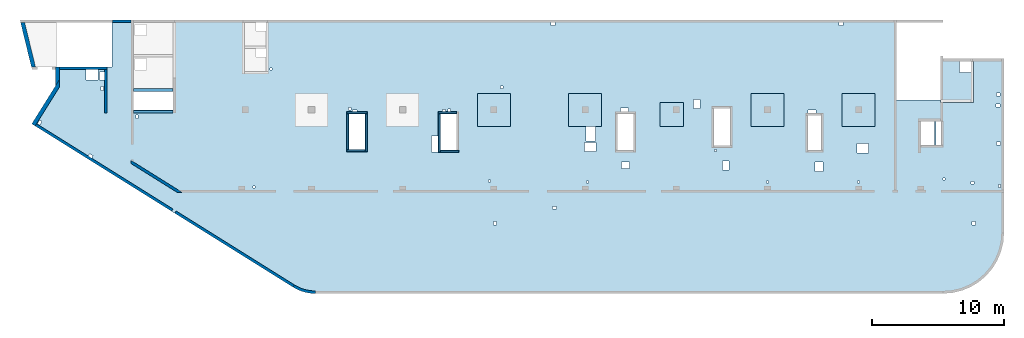
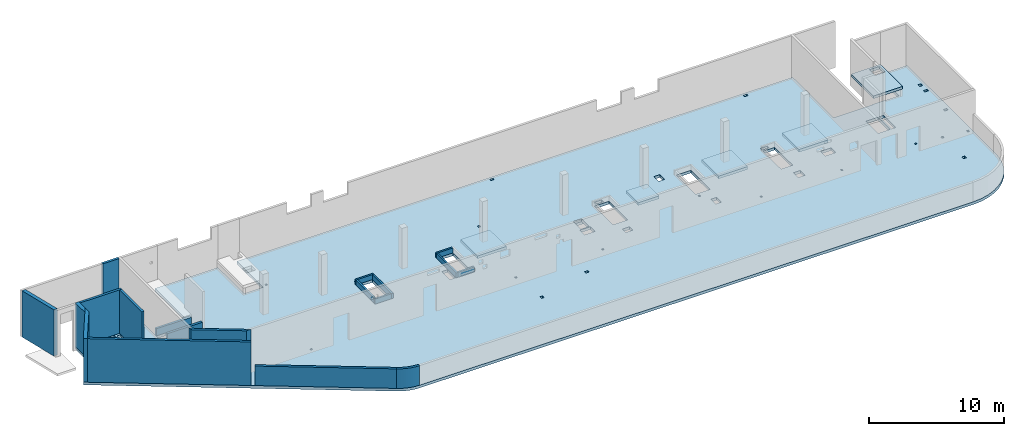
# One storey, part 2 of 6: 19 walls, 7 slabs.
"""IFC4 building model written with IfcOpenShell, lengths in millimetres."""

from ifc_helpers import new_model, entity, si_unit, converted_unit, derived_unit, direction, frame, origin, place, context, subcontext, project, spatial, indexed_curve, outline, extrude, material, type_object, element, save


model = new_model("IFC4")

# Units and contexts
model_context = context("Model", 3, precision=0.01, world=origin(), true_north=direction((6.12303176911189e-17, 1.0)))
plan_context = context("Plan", 3, precision=0.01, world=origin(), true_north=direction((6.12303176911189e-17, 1.0)))
body_context = subcontext(model_context, "Body", "Model", "MODEL_VIEW")
ifc_project = project(units=[si_unit("LENGTHUNIT", "METRE", prefix="MILLI"), si_unit("AREAUNIT", "SQUARE_METRE"), si_unit("VOLUMEUNIT", "CUBIC_METRE"), converted_unit("PLANEANGLEUNIT", "DEGREE", entity("IfcRatioMeasure", 0.0174532925199433), si_unit("PLANEANGLEUNIT", "RADIAN"), dimensions=[0, 0, 0, 0, 0, 0, 0]), si_unit("MASSUNIT", "GRAM", prefix="KILO"), derived_unit("MASSDENSITYUNIT", [(si_unit("MASSUNIT", "GRAM", prefix="KILO"), 1), (si_unit("LENGTHUNIT", "METRE"), -3)]), derived_unit("MOMENTOFINERTIAUNIT", [(si_unit("LENGTHUNIT", "METRE"), 4)]), si_unit("TIMEUNIT", "SECOND"), si_unit("FREQUENCYUNIT", "HERTZ"), si_unit("THERMODYNAMICTEMPERATUREUNIT", "DEGREE_CELSIUS"), derived_unit("THERMALTRANSMITTANCEUNIT", [(si_unit("MASSUNIT", "GRAM", prefix="KILO"), 1), (si_unit("THERMODYNAMICTEMPERATUREUNIT", "KELVIN"), -1), (si_unit("TIMEUNIT", "SECOND"), -3)]), derived_unit("VOLUMETRICFLOWRATEUNIT", [(si_unit("LENGTHUNIT", "METRE"), 3), (si_unit("TIMEUNIT", "SECOND"), -1)]), derived_unit("MASSFLOWRATEUNIT", [(si_unit("MASSUNIT", "GRAM", prefix="KILO"), 1), (si_unit("TIMEUNIT", "SECOND"), -1)]), derived_unit("ROTATIONALFREQUENCYUNIT", [(si_unit("TIMEUNIT", "SECOND"), -1)]), si_unit("ELECTRICCURRENTUNIT", "AMPERE"), si_unit("ELECTRICVOLTAGEUNIT", "VOLT"), si_unit("POWERUNIT", "WATT"), si_unit("FORCEUNIT", "NEWTON", prefix="KILO"), si_unit("ILLUMINANCEUNIT", "LUX"), si_unit("LUMINOUSFLUXUNIT", "LUMEN"), si_unit("LUMINOUSINTENSITYUNIT", "CANDELA"), derived_unit("USERDEFINED", [(si_unit("MASSUNIT", "GRAM", prefix="KILO"), -1), (si_unit("LENGTHUNIT", "METRE"), -2), (si_unit("TIMEUNIT", "SECOND"), 3), (si_unit("LUMINOUSFLUXUNIT", "LUMEN"), 1)]), derived_unit("LINEARVELOCITYUNIT", [(si_unit("LENGTHUNIT", "METRE"), 1), (si_unit("TIMEUNIT", "SECOND"), -1)]), si_unit("PRESSUREUNIT", "PASCAL"), derived_unit("USERDEFINED", [(si_unit("LENGTHUNIT", "METRE"), -2), (si_unit("MASSUNIT", "GRAM", prefix="KILO"), 1), (si_unit("TIMEUNIT", "SECOND"), -2)]), derived_unit("LINEARFORCEUNIT", [(si_unit("MASSUNIT", "GRAM", prefix="KILO"), 1), (si_unit("LENGTHUNIT", "METRE"), 1), (si_unit("TIMEUNIT", "SECOND"), -2), (si_unit("LENGTHUNIT", "METRE"), -1)]), derived_unit("PLANARFORCEUNIT", [(si_unit("MASSUNIT", "GRAM", prefix="KILO"), 1), (si_unit("LENGTHUNIT", "METRE"), 1), (si_unit("TIMEUNIT", "SECOND"), -2), (si_unit("LENGTHUNIT", "METRE"), -2)])], contexts=[model_context, plan_context])

# Site, building, storey
site_placement = place(None, origin())
site = spatial("IfcSite", under=ifc_project, at=site_placement, CompositionType="ELEMENT")
building_placement = place(site_placement, origin())
building = spatial("IfcBuilding", under=site, at=building_placement, CompositionType="ELEMENT")
storey_placement = place(building_placement, frame((0.0, 0.0, 28200.0)))
storey = spatial("IfcBuildingStorey", under=building, at=storey_placement, CompositionType="ELEMENT", Elevation=28200.0)

# Slabs
ifc_material = material()
slab_type_1 = type_object("IfcSlabType", PredefinedType="FLOOR", material=ifc_material)
slab_1_placement = place(storey_placement, origin())
element("IfcSlab", 1, at=slab_1_placement, inside=storey, type_object=slab_type_1, material=ifc_material, PredefinedType="FLOOR", context=body_context, shape_type="SweptSolid", body=[
    extrude(outline(indexed_curve([(-9938.81931383592, -15994.6889933943), (-9785.18945223826, -16084.8814308087), (-9626.77631531153, -16166.380438105), (-9464.0713398645, -16238.9331851656), (-9297.57927705262, -16302.3145953889), (-9127.81662651489, -16356.3280439333), (-8955.31003406395, -16400.8059676958), (-8780.59465790024, -16435.6103851342), (-8604.21250841868, -16460.6333243205), (-8426.71076675808, -16475.797157896), (-8248.64008730964, -16481.0548438912), (39261.8400680731, -16481.0548438912), (39981.4384793149, -16424.4212206982), (40683.3179894618, -16255.9148588784), (41350.1959955693, -15979.6849443003), (41965.6517478859, -15602.5331742155), (42514.530683209, -15133.7462768982), (42983.3175805262, -14584.8673415751), (43360.4693506111, -13969.4115892585), (43636.6992651892, -13302.533583151), (43805.205627009, -12600.6540730041), (43861.839250202, -11881.0556617623), (43861.839250202, 1288.94433823765), (41361.839250202, 1288.94433823766), (41361.839250202, -1811.05566176234), (39061.8400680731, -1811.05566176233), (39061.8400680731, -1851.05566176232), (35721.8400680731, -1851.05566176231), (35721.8400680732, 4218.94497760487), (-11983.1599319269, 4218.94497760503), (-11983.1599319269, 318.944338238026), (-13608.1599319269, 318.944338238032), (-13608.1599319269, 4218.94497760487), (-19008.1599319269, 4218.94497760488), (-19008.1599319269, -981.05502239514), (-22008.1599319269, -981.055022395131), (-22008.1599319269, 4218.94497760487), (-23638.1599319269, 4218.94497760487), (-23638.1599319269, 678.944338238106), (-27903.1599319269, 678.944338238122), (-27903.1599319269, -752.702496972901), (-29708.3002878078, -3641.58731781876), (-9938.81931383592, -15994.6889933943)], self_intersect=False), holes=[indexed_curve([(-24693.1599319269, 478.944338238115), (-24693.1599319269, -321.055661761885), (-25623.1599319269, -321.055661761885), (-25623.1599319269, 478.944338238115), (-24693.1599319269, 478.944338238115)], self_intersect=False), indexed_curve([(-24573.1599319269, -311.055661761892), (-24573.1599319269, 288.944338238108), (-24208.1599319269, 288.944338238108), (-24208.1599319269, -311.055661761892), (-24573.1599319269, -311.055661761892)], self_intersect=False), indexed_curve([(-24268.1599319269, -821.055661761893), (-24268.1599319269, -1121.05566176189), (-24468.1599319269, -1121.05566176189), (-24468.1599319269, -821.055661761893), (-24268.1599319269, -821.055661761893)], self_intersect=False), indexed_curve([(-29120.030322959, -3360.6274479853), (-28950.4197742035, -3466.6098132677), (-29109.3933221271, -3721.02563640098), (-29279.0038708826, -3615.04327111857), (-29120.030322959, -3360.6274479853)], self_intersect=False), indexed_curve([(-25332.3965852951, -5904.23328799078), (-25077.9807621618, -6063.20683591438), (-25183.9631274442, -6232.8173846699), (-25438.3789505775, -6073.84383674629), (-25332.3965852951, -5904.23328799078)], self_intersect=False), indexed_curve([(-21683.1599319269, -2966.05566176191), (-21683.1599319269, -3216.05566176191), (-21833.1599319269, -3216.05566176191), (-21833.1599319269, -2966.05566176191), (-21683.1599319269, -2966.05566176191)], self_intersect=False), indexed_curve([(-11548.1599319269, 573.944338238028), (-11548.1599319269, 423.944338238028), (-11698.1599319269, 423.944338238028), (-11698.1599319269, 573.944338238028), (-11548.1599319269, 573.944338238028)], self_intersect=False), indexed_curve([(43571.839250202, -2146.05566176235), (43571.839250202, -2346.05566176235), (43271.839250202, -2346.05566176235), (43271.839250202, -2146.05566176236), (43571.839250202, -2146.05566176235)], self_intersect=False), indexed_curve([(43561.839250202, -1291.05566176236), (43561.839250202, -1541.05566176236), (43311.839250202, -1541.05566176235), (43311.839250202, -1291.05566176236), (43561.839250202, -1291.05566176236)], self_intersect=False), indexed_curve([(43611.839250202, -5031.05566176235), (43611.839250202, -5231.05566176235), (43311.839250202, -5231.05566176235), (43311.839250202, -5031.05566176235), (43611.839250202, -5031.05566176235)], self_intersect=False), indexed_curve([(43586.839250202, -8246.05566176236), (43586.839250202, -8446.05566176236), (43436.839250202, -8446.05566176236), (43436.839250202, -8246.05566176236), (43586.839250202, -8246.05566176236)], self_intersect=False), indexed_curve([(41581.839250202, -7991.05566176235), (41581.839250202, -8191.05566176235), (41381.839250202, -8191.05566176235), (41381.839250202, -7991.05566176235), (41581.839250202, -7991.05566176235)], self_intersect=False), indexed_curve([(39396.8400680731, -7746.05566176233), (39396.8400680731, -7896.05566176233), (39246.8400680731, -7896.05566176233), (39246.8400680731, -7746.05566176233), (39396.8400680731, -7746.05566176233)], self_intersect=False), indexed_curve([(41686.839250202, -11031.0556617623), (41686.839250202, -11281.0556617623), (41436.839250202, -11281.0556617623), (41436.839250202, -11031.0556617623), (41686.839250202, -11031.0556617623)], self_intersect=False), indexed_curve([(5461.84006807309, -11031.0556617622), (5461.84006807309, -11281.0556617622), (5211.84006807308, -11281.0556617622), (5211.84006807309, -11031.0556617622), (5461.84006807309, -11031.0556617622)], self_intersect=False), indexed_curve([(10011.8400680731, -9881.05566176212), (10011.8400680731, -10081.0556617621), (9711.84006807309, -10081.0556617621), (9711.84006807309, -9881.05566176212), (10011.8400680731, -9881.05566176212)], self_intersect=False), indexed_curve([(32936.8400680731, -8101.05566176228), (32786.8400680731, -8101.05566176228), (32786.8400680731, -7951.05566176228), (32936.8400680731, -7951.05566176228), (32936.8400680731, -8101.05566176228)], self_intersect=False), indexed_curve([(33621.8400680731, -5141.05566176228), (33621.8400680731, -5841.05566176228), (32721.8400680731, -5841.05566176228), (32721.8400680731, -5141.05566176227), (33621.8400680731, -5141.05566176228)], self_intersect=False), indexed_curve([(30166.8400680731, -6541.05566176228), (30166.8400680731, -7241.05566176228), (29566.8400680731, -7241.05566176227), (29566.8400680731, -6541.05566176227), (30166.8400680731, -6541.05566176228)], self_intersect=False), indexed_curve([(26036.8400680731, -8101.05566176226), (25886.8400680731, -8101.05566176226), (25886.8400680731, -7951.05566176226), (26036.8400680731, -7951.05566176226), (26036.8400680731, -8101.05566176226)], self_intersect=False), indexed_curve([(12411.8400680731, -8121.05566176221), (12261.8400680731, -8121.05566176222), (12261.8400680731, -7971.05566176221), (12411.8400680731, -7971.05566176221), (12411.8400680731, -8121.05566176221)], self_intersect=False), indexed_curve([(5001.8400680731, -8041.05566176219), (4851.84006807309, -8041.05566176219), (4851.84006807309, -7891.05566176219), (5001.84006807309, -7891.05566176219), (5001.8400680731, -8041.05566176219)], self_intersect=False), indexed_curve([(-12818.1599319269, -8506.05566176197), (-12968.1599319269, -8506.05566176196), (-12968.1599319269, -8356.05566176196), (-12818.1599319269, -8356.05566176196), (-12818.1599319269, -8506.05566176197)], self_intersect=False), indexed_curve([(29021.8400680731, -5656.05566176226), (29021.8400680731, -2986.05566176226), (30021.8400680731, -2986.05566176226), (30021.8400680731, -5656.05566176226), (29021.8400680731, -5656.05566176226)], self_intersect=False), indexed_curve([(29021.8400680731, -2581.05566176225), (29621.8400680731, -2581.05566176225), (29621.8400680731, -2836.05566176225), (29021.8400680731, -2836.05566176226), (29021.8400680731, -2581.05566176225)], self_intersect=False), indexed_curve([(23041.8400680731, -6446.05566176221), (23041.8400680731, -7146.05566176222), (22541.8400680731, -7146.05566176222), (22541.8400680731, -6446.05566176221), (23041.8400680731, -6446.05566176221)], self_intersect=False), indexed_curve([(22096.8400680731, -5571.05566176221), (22096.8400680731, -5721.05566176221), (21946.8400680731, -5721.05566176221), (21946.8400680731, -5571.05566176221), (22096.8400680731, -5571.05566176221)], self_intersect=False), indexed_curve([(23141.8400680731, -2446.05566176221), (23141.8400680731, -5306.05566176222), (21881.8400680731, -5306.05566176221), (21881.8400680731, -2446.0556617622), (23141.8400680731, -2446.05566176221)], self_intersect=False), indexed_curve([(38611.8400680731, -3451.05566176231), (38611.8400680731, -5256.05566176231), (37571.8400680731, -5256.05566176231), (37571.8400680731, -3451.05566176231), (38611.8400680731, -3451.05566176231)], self_intersect=False), indexed_curve([(39111.8400680731, -3451.05566176232), (39111.8400680731, -5256.05566176232), (38731.8400680731, -5256.05566176232), (38731.8400680731, -3451.05566176232), (39061.8400680731, -3451.05566176232), (39111.8400680731, -3451.05566176232)], self_intersect=False), indexed_curve([(-4458.15993192693, -2881.05566176151), (-4458.15993192693, -5591.05566176151), (-5718.15993192693, -5591.05566176151), (-5718.15993192693, -2881.05566176151), (-4458.15993192693, -2881.05566176151)], self_intersect=False), indexed_curve([(-5088.15993192693, -2581.05566176152), (-5088.15993192693, -2731.05566176152), (-5438.15993192692, -2731.05566176152), (-5438.15993192693, -2581.05566176151), (-5088.15993192693, -2581.05566176152)], self_intersect=False), indexed_curve([(-5538.15993192693, -2391.05566176151), (-5538.15993192693, -2591.05566176151), (-5738.15993192693, -2591.05566176151), (-5738.15993192693, -2391.05566176151), (-5538.15993192693, -2391.05566176151)], self_intersect=False), indexed_curve([(1616.84006807306, -2561.05566176154), (1616.84006807306, -2711.05566176153), (1366.84006807306, -2711.05566176153), (1366.84006807306, -2561.05566176153), (1616.84006807306, -2561.05566176154)], self_intersect=False), indexed_curve([(2461.84006807306, -2881.05566176156), (2461.84006807306, -5656.05566176156), (1201.84006807306, -5656.05566176156), (1201.84006807307, -2881.05566176156), (2461.84006807306, -2881.05566176156)], self_intersect=False), indexed_curve([(1981.84006807306, -2531.05566176156), (1981.84006807306, -2731.05566176156), (1781.84006807306, -2731.05566176156), (1781.84006807306, -2531.05566176156), (1981.84006807306, -2531.05566176156)], self_intersect=False), indexed_curve([(1031.84006807307, -4561.05566176155), (1031.84006807307, -5761.05566176155), (531.840068073072, -5761.05566176155), (531.840068073072, -4561.05566176155), (1031.84006807307, -4561.05566176155)], self_intersect=False), indexed_curve([(5961.84006807306, -771.055661761588), (5961.84006807306, -971.055661761588), (5761.84006807306, -971.055661761592), (5761.84006807306, -771.05566176159), (5961.84006807306, -771.055661761588)], self_intersect=False), indexed_curve([(12946.8400680731, -3831.05566176163), (12946.8400680731, -4951.05566176164), (12246.8400680731, -4951.05566176163), (12246.8400680731, -3831.05566176163), (12946.8400680731, -3831.05566176163)], self_intersect=False), indexed_curve([(13001.8400680731, -5046.05566176163), (13001.8400680731, -5746.05566176164), (12101.8400680731, -5746.05566176163), (12101.8400680731, -5046.05566176163), (13001.8400680731, -5046.05566176163)], self_intersect=False), indexed_curve([(15861.8400680731, -2881.05566176161), (15861.8400680731, -5656.05566176161), (14601.8400680731, -5656.05566176161), (14601.8400680731, -2881.05566176162), (15861.8400680731, -2881.05566176161)], self_intersect=False), indexed_curve([(15461.8400680731, -2451.05566176165), (15461.8400680731, -2731.05566176162), (14831.8400680731, -2731.05566176162), (14831.8400680731, -2451.05566176165), (15461.8400680731, -2451.05566176165)], self_intersect=False), indexed_curve([(15516.8400680731, -6511.05566176205), (15516.8400680731, -7011.05566176205), (14916.8400680731, -7011.05566176205), (14916.8400680731, -6511.05566176205), (15516.8400680731, -6511.05566176205)], self_intersect=False), indexed_curve([(20856.8400680731, -1786.05566176169), (20856.8400680731, -2486.05566176169), (20356.8400680731, -2486.05566176169), (20356.8400680731, -1786.0556617617), (20856.8400680731, -1786.05566176169)], self_intersect=False), indexed_curve([(9891.84006807312, 4018.94497760487), (9891.84006807312, 3818.94497760487), (9591.84006807312, 3818.94497760487), (9591.84006807312, 4018.94497760487), (9891.84006807312, 4018.94497760487)], self_intersect=False), indexed_curve([(31661.8400680731, 4018.944977605), (31661.8400680731, 3818.94497760499), (31361.8400680731, 3818.94497760499), (31361.8400680731, 4018.94497760499), (31661.8400680731, 4018.944977605)], self_intersect=False), indexed_curve([(-19008.1599319269, -1181.05502239513), (-19008.1599319269, -2581.05502239513), (-22008.1599319269, -2581.05502239513), (-22008.1599319269, -1181.05502239513), (-19008.1599319269, -1181.05502239513)], self_intersect=False)]), frame((29708.1602004816, 16281.0548881178, -400.0)), (0.0, 0.0, 1.0), 249.999999999999),
])
slab_type_2 = type_object("IfcSlabType", PredefinedType="FLOOR", material=ifc_material)
slab_2_placement = place(storey_placement, origin())
element("IfcSlab", 2, at=slab_2_placement, inside=storey, type_object=slab_type_2, material=ifc_material, PredefinedType="FLOOR", context=body_context, shape_type="SweptSolid", body=[
    extrude(outline(indexed_curve([(-1133.33296983506, -1466.66666666666), (-933.332969835079, -1466.66666666666), (1166.66621229381, -1466.66666666666), (1366.66621229383, -1466.66666666666), (1366.66621229383, 1633.33333333332), (1366.66621229383, 1833.33333333332), (-933.33296983507, 1833.33333333332), (-1133.33296983506, 1833.33333333332), (-1133.33296983506, -1266.66666666668), (-1133.33296983506, -1466.66666666666)], self_intersect=False), holes=[indexed_curve([(-933.33296983507, -1266.66666666667), (-933.33296983507, -416.666666666674), (-83.332969835073, -416.666666666674), (-83.332969835073, -1266.66666666667), (-933.33296983507, -1266.66666666667)], self_intersect=False)]), frame((70136.6664808485, 16103.3325596888, 500.0), z_axis=(0.0, 0.0, 1.0), x_axis=(-1.0, 0.0, 0.0)), (0.0, 0.0, 1.0), 249.999999999999),
])
slab_type_3 = type_object("IfcSlabType", PredefinedType="FLOOR", material=ifc_material)
slab_3_placement = place(storey_placement, origin())
element("IfcSlab", 3, at=slab_3_placement, inside=storey, type_object=slab_type_3, material=ifc_material, PredefinedType="FLOOR", context=body_context, shape_type="SweptSolid", body=[
    extrude(outline(indexed_curve([(-1250.0, -1250.0), (1250.0, -1250.0), (1250.0, 1250.0), (-1250.0, 1250.0), (-1250.0, -1250.0)], self_intersect=False)), frame((34970.0002685547, 13699.9992263563, -400.0), z_axis=(0.0, 0.0, -1.0), x_axis=(0.0, 1.0, 0.0)), (0.0, 0.0, 1.0), 249.999999999999),
])
slab_type_4 = type_object("IfcSlabType", PredefinedType="FLOOR", material=ifc_material)
slab_4_placement = place(storey_placement, origin())
element("IfcSlab", 4, at=slab_4_placement, inside=storey, type_object=slab_type_4, material=ifc_material, PredefinedType="FLOOR", context=body_context, shape_type="SweptSolid", body=[
    extrude(outline(indexed_curve([(-1250.0, -1250.0), (1250.0, -1250.0), (1250.0, 1250.0), (-1250.0, 1250.0), (-1250.0, -1250.0)], self_intersect=False)), frame((41870.0002685547, 13699.9992263563, -400.0), z_axis=(0.0, 0.0, -1.0), x_axis=(0.0, 1.0, 0.0)), (0.0, 0.0, 1.0), 249.999999999999),
])
slab_type_5 = type_object("IfcSlabType", PredefinedType="FLOOR", material=ifc_material)
slab_5_placement = place(storey_placement, origin())
element("IfcSlab", 5, at=slab_5_placement, inside=storey, type_object=slab_type_5, material=ifc_material, PredefinedType="FLOOR", context=body_context, shape_type="SweptSolid", body=[
    extrude(outline(indexed_curve([(-899.999999999934, -900.000000000003), (899.999999999936, -900.000000000003), (899.999999999936, 900.000000000003), (-899.999999999934, 900.000000000003), (-899.999999999934, -900.000000000003)], self_intersect=False)), frame((48420.0002685547, 13349.9992263562, -400.0), z_axis=(0.0, 0.0, -1.0), x_axis=(0.0, 1.0, 0.0)), (0.0, 0.0, 1.0), 249.999999999999),
])
slab_type_6 = type_object("IfcSlabType", PredefinedType="FLOOR", material=ifc_material)
slab_6_placement = place(storey_placement, origin())
element("IfcSlab", 6, at=slab_6_placement, inside=storey, type_object=slab_type_6, material=ifc_material, PredefinedType="FLOOR", context=body_context, shape_type="SweptSolid", body=[
    extrude(outline(indexed_curve([(-1250.0, -1250.00000000001), (1250.0, -1250.00000000001), (1250.0, 1249.99999999999), (-1250.0, 1249.99999999999), (-1250.0, -1250.00000000001)], self_intersect=False)), frame((55670.0002685547, 13699.9992263562, -400.0), z_axis=(0.0, 0.0, -1.0), x_axis=(0.0, 1.0, 0.0)), (0.0, 0.0, 1.0), 249.999999999999),
])
slab_type_7 = type_object("IfcSlabType", PredefinedType="FLOOR", material=ifc_material)
slab_7_placement = place(storey_placement, origin())
element("IfcSlab", 7, at=slab_7_placement, inside=storey, type_object=slab_type_7, material=ifc_material, PredefinedType="FLOOR", context=body_context, shape_type="SweptSolid", body=[
    extrude(outline(indexed_curve([(-1250.0, -1249.99999999999), (1250.0, -1249.99999999999), (1250.0, 1250.00000000001), (-1250.0, 1250.00000000001), (-1250.0, -1249.99999999999)], self_intersect=False)), frame((62570.0002685546, 13699.9992263562, -400.0), z_axis=(0.0, 0.0, -1.0), x_axis=(0.0, 1.0, 0.0)), (0.0, 0.0, 1.0), 249.999999999999),
])

# Walls
wall_type_1 = type_object("IfcWallType", PredefinedType="STANDARD")
wall_1_placement = place(storey_placement, frame((2105.00026855469, 16859.9992263559, -150.0)))
element("IfcWall", 8, at=wall_1_placement, inside=storey, type_object=wall_type_1, material=ifc_material, PredefinedType="NOTDEFINED", context=body_context, shape_type="SweptSolid", body=[
    extrude(outline(indexed_curve([(3595.0, 99.9999999999979), (-6.29008184861995e-14, 99.9999999999989), (6.29008184861995e-14, -99.9999999999989), (3595.0, -99.9999999999999), (3595.0, 99.9999999999979)], self_intersect=False)), origin(), (0.0, 0.0, 1.0), 3950.0),
])
wall_2_placement = place(storey_placement, frame((5600.0002685547, 16759.9992263559, -150.0), z_axis=(0.0, 0.0, 1.0), x_axis=(0.0, -1.0, 0.0)))
element("IfcWall", 9, at=wall_2_placement, inside=storey, type_object=wall_type_1, material=ifc_material, PredefinedType="NOTDEFINED", context=body_context, shape_type="SweptSolid", body=[
    extrude(outline(indexed_curve([(3310.00000000004, 99.9999999999997), (-1.54254576823131e-13, 100.0), (1.54254576823131e-13, -100.0), (3310.00000000004, -100.0), (3310.00000000004, 99.9999999999997)], self_intersect=False)), origin(), (0.0, 0.0, 1.0), 3950.0),
])
wall_3_placement = place(storey_placement, frame((307.266918448291, 12565.2992967532, -150.0), z_axis=(0.0, 0.0, 1.0), x_axis=(0.848052743777574, -0.529911826412026, 0.0)))
element("IfcWall", 10, at=wall_3_placement, inside=storey, type_object=wall_type_1, material=ifc_material, PredefinedType="NOTDEFINED", context=body_context, shape_type="SweptSolid", body=[
    extrude(outline(indexed_curve([(12172.7700242045, 100.000000000001), (-2.62256882876955e-13, 100.0), (3.2147617901046e-13, -100.0), (12172.7700242045, -100.0), (12172.7700242045, 100.000000000001)], self_intersect=False)), origin(), (0.0, 0.0, 1.0), 3950.0),
])
wall_4_placement = place(storey_placement, frame((7447.00908591348, 9790.19618041956, -150.0), z_axis=(0.0, 0.0, 1.0), x_axis=(0.848052743777574, -0.529911826412026, 0.0)))
element("IfcWall", 11, at=wall_4_placement, inside=storey, type_object=wall_type_1, material=ifc_material, PredefinedType="NOTDEFINED", context=body_context, shape_type="SweptSolid", body=[
    extrude(outline(indexed_curve([(4256.16407725215, -99.9999999999989), (4576.23722961777, 100.000000000002), (4198.81594926216, 100.000000000002), (235.834388211653, 100.000000000003), (-9.47508738136094e-13, 100.000000000003), (124.971431388001, -99.9999999999987), (4256.16407725215, -99.9999999999989)], self_intersect=False)), origin(), (0.0, 0.0, 1.0), 3950.0),
])
wall_5_placement = place(storey_placement, frame((10875.2597874089, 5961.81331809222, -150.0), z_axis=(0.0, 0.0, 1.0), x_axis=(0.848052743777574, -0.529911826412025, 0.0)))
element("IfcWall", 12, at=wall_5_placement, inside=storey, type_object=wall_type_1, material=ifc_material, PredefinedType="NOTDEFINED", context=body_context, shape_type="SweptSolid", body=[
    extrude(outline(indexed_curve([(10550.8352599265, 99.9999999999989), (-7.02171654154427e-13, 100.0), (7.02171654154427e-13, -100.0), (10550.8352599265, -100.000000000002), (10550.8352599265, 99.9999999999989)], self_intersect=False)), origin(), (0.0, 0.0, 1.0), 1770.0),
])
wall_6_placement = place(storey_placement, frame((19822.9245382981, 370.800870618764, -150.0)))
element("IfcWall", 13, at=wall_6_placement, inside=storey, type_object=wall_type_1, material=ifc_material, PredefinedType="NOTDEFINED", context=body_context, shape_type="SweptSolid", body=[
    extrude(outline(indexed_curve([(1641.92023350293, -370.805258501397), (1474.54329430422, -366.130070716584), (1307.68829895409, -352.119086344867), (1141.87556368517, -328.81599687171), (977.622154573621, -296.293470038928), (815.4402751339, -254.652923239516), (655.835669076768, -204.024207260316), (499.306043211407, -144.565201358734), (346.339515409568, -76.4613209362117), (197.413092471656, 0.0750606562846201), (52.9911826412194, 84.805274377746), (-52.991182641202, -84.8052743777568), (101.063741069954, -175.187035886212), (259.923631173975, -256.828432549666), (423.093103164338, -329.47487598227), (590.063333647626, -392.899827423948), (760.31364704501, -446.905504172905), (933.313139253311, -491.323496346018), (1108.52233320239, -526.015292043783), (1285.39486114626, -550.872709282183), (1463.37916844194, -565.818233344545), (1641.92023350291, -570.805258501397), (1641.92023350293, -370.805258501397)], self_intersect=False)), origin(), (0.0, 0.0, 1.0), 1770.0),
])
wall_7_placement = place(storey_placement, frame((6100.0002685547, 20399.9998657227, -150.0)))
element("IfcWall", 14, at=wall_7_placement, inside=storey, type_object=wall_type_1, material=ifc_material, PredefinedType="NOTDEFINED", context=body_context, shape_type="SweptSolid", body=[
    extrude(outline(indexed_curve([(1400.0, 99.9999999999989), (-3.09390608370965e-13, 99.9999999999989), (3.09390608370965e-13, -99.9999999999989), (1400.0, -99.9999999999989), (1400.0, 99.9999999999989)], self_intersect=False)), origin(), (0.0, 0.0, 1.0), 3950.0),
])
wall_8_placement = place(storey_placement, frame((7700.00026855469, 15199.9998657227, -150.0)))
element("IfcWall", 15, at=wall_8_placement, inside=storey, type_object=wall_type_1, material=ifc_material, PredefinedType="NOTDEFINED", context=body_context, shape_type="SweptSolid", body=[
    extrude(outline(indexed_curve([(2999.99999999999, 99.9999999999989), (-2.88764567812902e-13, 99.9999999999989), (2.88764567812902e-13, -99.9999999999989), (2999.99999999999, -99.9999999999989), (2999.99999999999, 99.9999999999989)], self_intersect=False)), origin(), (0.0, 0.0, 1.0), 650.0),
])
wall_9_placement = place(storey_placement, frame((10700.0002685547, 13549.9992263559, -150.0), z_axis=(0.0, 0.0, 1.0), x_axis=(-1.0, 0.0, 0.0)))
element("IfcWall", 16, at=wall_9_placement, inside=storey, type_object=wall_type_1, material=ifc_material, PredefinedType="NOTDEFINED", context=body_context, shape_type="SweptSolid", body=[
    extrude(outline(indexed_curve([(3000.0, 99.9999999999984), (-3.44878351568426e-13, 99.9999999999989), (3.44878351568426e-13, -99.9999999999989), (3000.0, -99.9999999999994), (3000.0, 99.9999999999984)], self_intersect=False)), origin(), (0.0, 0.0, 1.0), 1200.0),
])
wall_type_2 = type_object("IfcWallType", PredefinedType="STANDARD")
wall_10_placement = place(storey_placement, frame((127.067824240451, 12559.9807963372, -150.0), z_axis=(0.0, 0.0, 1.0), x_axis=(0.529911826412024, 0.848052743777575, 0.0)))
element("IfcWall", 17, at=wall_10_placement, inside=storey, type_object=wall_type_2, material=ifc_material, PredefinedType="NOTDEFINED", context=body_context, shape_type="SweptSolid", body=[
    extrude(outline(indexed_curve([(3492.51411367559, -150.0), (3972.62384222401, 150.0), (3406.49192169061, 150.000000000001), (1.99653626964391e-12, 150.0), (3.2147617901046e-13, -150.0), (200.000000000003, -149.999999999999), (3492.51411367559, -150.0)], self_intersect=False)), origin(), (0.0, 0.0, 1.0), 3950.0),
])
wall_11_placement = place(storey_placement, frame((1955.00026855469, 15528.3523911449, -150.0), z_axis=(0.0, 0.0, 1.0), x_axis=(0.0, 1.0, 0.0)))
element("IfcWall", 18, at=wall_11_placement, inside=storey, type_object=wall_type_2, material=ifc_material, PredefinedType="NOTDEFINED", context=body_context, shape_type="SweptSolid", body=[
    extrude(outline(indexed_curve([(1431.64683521101, -150.0), (1431.64683521101, 150.0), (-2.46541530600305e-13, 150.0), (480.109728548418, -150.0), (1231.64683521101, -150.0), (1431.64683521101, -150.0)], self_intersect=False)), origin(), (0.0, 0.0, 1.0), 3950.0),
])
wall_12_placement = place(storey_placement, frame((133.585227322228, 16924.4753124074, -400.0), z_axis=(0.0, 0.0, 1.0), x_axis=(-0.236826092990336, 0.971552058141473, 0.0)))
element("IfcWall", 19, at=wall_12_placement, inside=storey, type_object=wall_type_2, material=ifc_material, PredefinedType="NOTDEFINED", context=body_context, shape_type="SweptSolid", body=[
    extrude(outline(indexed_curve([(3437.79894384249, -150.0), (3510.92711777998, 150.0), (73.1281739374955, 150.0), (7.65620900011754e-13, -150.0), (3437.79894384249, -150.0)], self_intersect=False)), origin(), (0.0, 0.0, 1.0), 4200.0),
])
wall_type_3 = type_object("IfcWallType", PredefinedType="STANDARD")
wall_13_placement = place(storey_placement, frame((23840.0002685547, 13474.9992263563, -150.0)))
element("IfcWall", 20, at=wall_13_placement, inside=storey, type_object=wall_type_3, material=ifc_material, PredefinedType="NOTDEFINED", context=body_context, shape_type="SweptSolid", body=[
    extrude(outline(indexed_curve([(1560.0, 75.0000000000013), (-2.57825506975809e-13, 75.0000000000003), (2.57825506975809e-13, -75.0000000000003), (1560.0, -74.9999999999992), (1560.0, 75.0000000000013)], self_intersect=False)), origin(), (0.0, 0.0, 1.0), 450.000000000002),
])
wall_14_placement = place(storey_placement, frame((25325.0002685547, 13399.9992263563, -150.0), z_axis=(0.0, 0.0, 1.0), x_axis=(0.0, -1.0, 0.0)))
element("IfcWall", 21, at=wall_14_placement, inside=storey, type_object=wall_type_3, material=ifc_material, PredefinedType="NOTDEFINED", context=body_context, shape_type="SweptSolid", body=[
    extrude(outline(indexed_curve([(2859.99999999999, 75.0000000000005), (-1.19874589959232e-13, 75.0000000000003), (1.19874589959232e-13, -75.0000000000003), (2859.99999999999, -75.0), (2859.99999999999, 75.0000000000005)], self_intersect=False)), origin(), (0.0, 0.0, 1.0), 450.000000000002),
])
wall_15_placement = place(storey_placement, frame((25250.0002685547, 10614.9992263563, -150.0), z_axis=(0.0, 0.0, 1.0), x_axis=(-1.0, 0.0, 0.0)))
element("IfcWall", 22, at=wall_15_placement, inside=storey, type_object=wall_type_3, material=ifc_material, PredefinedType="NOTDEFINED", context=body_context, shape_type="SweptSolid", body=[
    extrude(outline(indexed_curve([(1410.0, 75.0000000000008), (-2.5782550697581e-13, 75.0000000000003), (2.5782550697581e-13, -75.0000000000003), (1410.0, -74.9999999999998), (1410.0, 75.0000000000008)], self_intersect=False)), origin(), (0.0, 0.0, 1.0), 450.000000000002),
])
wall_16_placement = place(storey_placement, frame((23915.0002685547, 10689.9992263563, -150.0), z_axis=(0.0, 0.0, 1.0), x_axis=(0.0, 1.0, 0.0)))
element("IfcWall", 23, at=wall_16_placement, inside=storey, type_object=wall_type_3, material=ifc_material, PredefinedType="NOTDEFINED", context=body_context, shape_type="SweptSolid", body=[
    extrude(outline(indexed_curve([(2709.99999999999, 75.0000000000003), (0.0, 75.0000000000003), (0.0, -75.0000000000003), (2709.99999999999, -75.0000000000003), (2709.99999999999, 75.0000000000003)], self_intersect=False)), origin(), (0.0, 0.0, 1.0), 450.000000000002),
])
wall_17_placement = place(storey_placement, frame((30760.0002685547, 13474.9992263562, -150.0)))
element("IfcWall", 24, at=wall_17_placement, inside=storey, type_object=wall_type_3, material=ifc_material, PredefinedType="NOTDEFINED", context=body_context, shape_type="SweptSolid", body=[
    extrude(outline(indexed_curve([(1410.0, 75.0000000000003), (0.0, 75.0000000000003), (0.0, -75.0000000000003), (1410.0, -75.0000000000003), (1410.0, 75.0000000000003)], self_intersect=False)), origin(), (0.0, 0.0, 1.0), 450.000000000002),
])
wall_18_placement = place(storey_placement, frame((30835.0002685547, 10474.9992263562, -150.0), z_axis=(0.0, 0.0, 1.0), x_axis=(0.0, 1.0, 0.0)))
element("IfcWall", 25, at=wall_18_placement, inside=storey, type_object=wall_type_3, material=ifc_material, PredefinedType="NOTDEFINED", context=body_context, shape_type="SweptSolid", body=[
    extrude(outline(indexed_curve([(2925.0, 75.0000000000003), (0.0, 75.0000000000003), (0.0, -75.0000000000003), (2925.0, -75.0000000000003), (2925.0, 75.0000000000003)], self_intersect=False)), origin(), (0.0, 0.0, 1.0), 450.000000000002),
])
wall_19_placement = place(storey_placement, frame((32320.0002685547, 10549.9992263562, -150.0), z_axis=(0.0, 0.0, 1.0), x_axis=(-1.0, 0.0, 0.0)))
element("IfcWall", 26, at=wall_19_placement, inside=storey, type_object=wall_type_3, material=ifc_material, PredefinedType="NOTDEFINED", context=body_context, shape_type="SweptSolid", body=[
    extrude(outline(indexed_curve([(1410.0, 75.0000000000003), (0.0, 75.0000000000003), (0.0, -75.0000000000003), (1410.0, -75.0000000000003), (1410.0, 75.0000000000003)], self_intersect=False)), origin(), (0.0, 0.0, 1.0), 450.000000000002),
])

save(model, "model.ifc")
